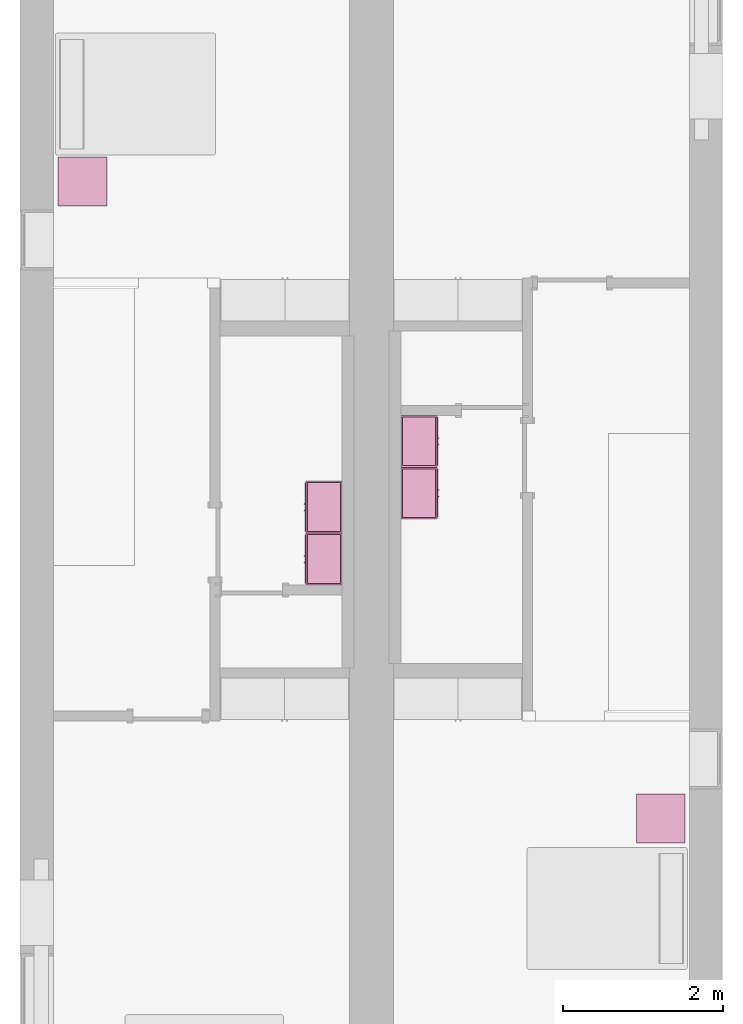
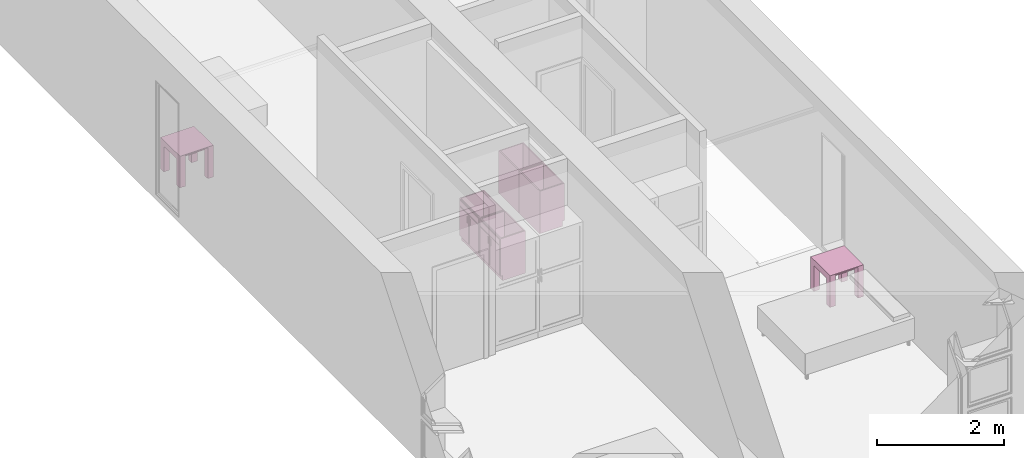
# One storey, part 10 of 16: 6 furnishings.
"""IFC2X3 building model written with IfcOpenShell, lengths in metres."""

import ifcopenshell
import ifcopenshell.guid

model = None  # the IFC model being written
_history = None  # IfcOwnerHistory: only IFC2X3 demands one
_inside = {}  # id of a spatial element -> (the spatial element, [elements in it])
_under = {}  # id of a project, library or spatial element -> (it, [spatial elements below it])
_declared = {}  # id of a project -> (the project, [libraries it declares])
_typed = {}  # id of a type object -> (the type object, [elements of that type])
_made_of = {}  # id of a material, layer set ... -> (it, [elements and type objects made of it])


def new_model(schema):
    """Start an empty IFC model of exactly this schema.

    Asked for "IFC4X3", IfcOpenShell would pick the latest addendum, in which some entities
    have other attributes; the version numbers below select the first issue.
    IFC2X3 requires an IfcOwnerHistory on every rooted entity: one is made here for all.
    """
    global model, _history
    if schema == "IFC4X3":
        model = ifcopenshell.file(schema_version=(4, 3, 0, 0))
    else:
        model = ifcopenshell.file(schema=schema)
    _inside.clear()
    _under.clear()
    _declared.clear()
    _typed.clear()
    _made_of.clear()
    _history = None
    if model.schema == "IFC2X3":
        org = make("IfcOrganization", Name="unknown")
        user = make(
            "IfcPersonAndOrganization",
            ThePerson=make("IfcPerson", FamilyName="unknown"),
            TheOrganization=org,
        )
        app = make(
            "IfcApplication",
            ApplicationDeveloper=org,
            Version="unknown",
            ApplicationFullName="unknown",
            ApplicationIdentifier="unknown",
        )
        _history = make(
            "IfcOwnerHistory",
            OwningUser=user,
            OwningApplication=app,
            ChangeAction="ADDED",
            CreationDate=0,
        )
    return model


def make(cls, **values):
    """One entity of the class cls with the attributes given. An attribute that is None is left unset."""
    return model.create_entity(
        cls, **{name: value for name, value in values.items() if value is not None}
    )


def entity(cls, *values):
    """Any entity or typed value of the class cls, its attributes in the order of the schema. None: left unset."""
    e = model.create_entity(cls)
    for i, value in enumerate(values):
        if value is not None:
            e[i] = value
    return e


def rooted(cls, **values):
    """An entity with a GlobalId (a new one), such as an element, a storey or a relation."""
    return make(cls, GlobalId=ifcopenshell.guid.new(), OwnerHistory=_history, **values)


def si_unit(unit_type, name, prefix=None):
    """IfcSIUnit, for example si_unit("LENGTHUNIT", "METRE", prefix="MILLI")."""
    return make("IfcSIUnit", UnitType=unit_type, Prefix=prefix, Name=name)


def converted_unit(unit_type, name, factor, base, dimensions=None, offset=None):
    """IfcConversionBasedUnit, such as the inch: factor (a typed value) times the base unit."""
    return make(
        "IfcConversionBasedUnit"
        if offset is None
        else "IfcConversionBasedUnitWithOffset",
        ConversionOffset=offset,
        Dimensions=None
        if dimensions is None
        else entity("IfcDimensionalExponents", *dimensions),
        UnitType=unit_type,
        Name=name,
        ConversionFactor=make(
            "IfcMeasureWithUnit", ValueComponent=factor, UnitComponent=base
        ),
    )


def assignment(units):
    """IfcUnitAssignment: the units of a project."""
    return None if units is None else make("IfcUnitAssignment", Units=units)


def point(xyz):
    """IfcCartesianPoint."""
    return None if xyz is None else make("IfcCartesianPoint", Coordinates=xyz)


def direction(xyz):
    """IfcDirection."""
    return None if xyz is None else make("IfcDirection", DirectionRatios=xyz)


def frame(location, z_axis=None, x_axis=None):
    """IfcAxis2Placement3D, a coordinate frame: its origin and axes. An axis left out is left unset."""
    return make(
        "IfcAxis2Placement3D",
        Location=point(location),
        Axis=direction(z_axis),
        RefDirection=direction(x_axis),
    )


def frame_2d(location, x_axis=None):
    """IfcAxis2Placement2D, a coordinate frame in the plane: its origin and x axis."""
    return make(
        "IfcAxis2Placement2D", Location=point(location), RefDirection=direction(x_axis)
    )


def origin():
    """The frame at (0, 0, 0) with its axes left unset."""
    return frame((0.0, 0.0, 0.0))


def origin_2d_with_axis():
    """The frame at (0, 0) in the plane with the x axis (1, 0) written out."""
    return frame_2d((0.0, 0.0), x_axis=(1.0, 0.0))


def place(relative_to, where):
    """IfcLocalPlacement: puts the frame where relative to a parent placement (None: the world)."""
    return make(
        "IfcLocalPlacement", PlacementRelTo=relative_to, RelativePlacement=where
    )


def context(
    kind, dimensions, precision=None, world=None, true_north=None, identifier=None
):
    """IfcGeometricRepresentationContext, for example the 3D "Model" context."""
    return make(
        "IfcGeometricRepresentationContext",
        ContextIdentifier=identifier,
        ContextType=kind,
        CoordinateSpaceDimension=dimensions,
        Precision=precision,
        WorldCoordinateSystem=world,
        TrueNorth=true_north,
    )


def project(units=None, contexts=None):
    """IfcProject with its units and contexts."""
    return rooted(
        "IfcProject",
        Name="project",
        RepresentationContexts=contexts,
        UnitsInContext=assignment(units),
    )


def spatial(cls, under=None, at=None, **own):
    """A site, building, storey or space (cls), placed at a placement, below another one or the project."""
    s = rooted(cls, ObjectPlacement=at, **own)
    if under is not None:
        _under.setdefault(under.id(), (under, []))[1].append(s)
    return s


def polyline(points):
    """IfcPolyline through the points."""
    return make("IfcPolyline", Points=[point(p) for p in points])


def profile(cls, at=None, kind="AREA", **sizes):
    """A parametric profile (cls). Its sizes go by their IFC names, for example OverallWidth=200.0."""
    return make(cls, ProfileType=kind, Position=at, **sizes)


def rectangle(**sizes):
    """IfcRectangleProfileDef."""
    return profile("IfcRectangleProfileDef", **sizes)


def outline(outer, holes=None, kind="AREA"):
    """IfcArbitraryClosedProfileDef: a profile drawn as a closed curve; with holes, ...WithVoids."""
    if holes is None:
        return make("IfcArbitraryClosedProfileDef", ProfileType=kind, OuterCurve=outer)
    return make(
        "IfcArbitraryProfileDefWithVoids",
        ProfileType=kind,
        OuterCurve=outer,
        InnerCurves=holes,
    )


def extrude(swept, where, along, depth):
    """IfcExtrudedAreaSolid: the profile swept, set in the frame where, extruded along a direction by depth."""
    return make(
        "IfcExtrudedAreaSolid",
        SweptArea=swept,
        Position=where,
        ExtrudedDirection=direction(along),
        Depth=depth,
    )


def faces_of(points, faces, orient=None, outer=None):
    """IfcFace entities. A face is a list of loops; a loop is a list of indices into points, from 0.

    orient and outer hold one flag for each loop. By default every Orientation is true, the
    first loop of a face is its IfcFaceOuterBound and the others are IfcFaceBound.
    """
    made = []
    for i, loops in enumerate(faces):
        bounds = []
        for j, loop in enumerate(loops):
            is_outer = j == 0 if outer is None else outer[i][j]
            bounds.append(
                make(
                    "IfcFaceOuterBound" if is_outer else "IfcFaceBound",
                    Bound=make("IfcPolyLoop", Polygon=[points[k] for k in loop]),
                    Orientation=True if orient is None else orient[i][j],
                )
            )
        made.append(make("IfcFace", Bounds=bounds))
    return made


def face_set(faces, orient=None, outer=None):
    """The faces of one IfcConnectedFaceSet. surface_model builds it on its shared points."""
    return ("IfcConnectedFaceSet", faces, orient, outer)


def surface_model(cls, points, shells):
    """IfcFaceBasedSurfaceModel or IfcShellBasedSurfaceModel (cls): surfaces that need not close."""
    shared = [point(p) for p in points]
    made = [make(c, CfsFaces=faces_of(shared, fs, o, b)) for c, fs, o, b in shells]
    if cls == "IfcFaceBasedSurfaceModel":
        return make(cls, FbsmFaces=made)
    return make(cls, SbsmBoundary=made)


def shape(context_of_items, identifier, shape_type, items):
    """IfcShapeRepresentation: the items that make up one representation, for example the "Body"."""
    return make(
        "IfcShapeRepresentation",
        ContextOfItems=context_of_items,
        RepresentationIdentifier=identifier,
        RepresentationType=shape_type,
        Items=items,
    )


def source(mapping_origin, context_of_items, identifier, shape_type, items):
    """IfcRepresentationMap: a shape defined once, which mapped items show again and again."""
    return make(
        "IfcRepresentationMap",
        MappingOrigin=mapping_origin,
        MappedRepresentation=shape(context_of_items, identifier, shape_type, items),
    )


def transform(
    local_origin,
    x_axis=None,
    y_axis=None,
    z_axis=None,
    scale=None,
    scale2=None,
    scale3=None,
    uniform=True,
):
    """IfcCartesianTransformationOperator3D, or its non-uniform kind. x_axis, y_axis, z_axis: its Axis1, 2, 3."""
    if uniform:
        return make(
            "IfcCartesianTransformationOperator3D",
            Axis1=direction(x_axis),
            Axis2=direction(y_axis),
            LocalOrigin=point(local_origin),
            Scale=scale,
            Axis3=direction(z_axis),
        )
    return make(
        "IfcCartesianTransformationOperator3DnonUniform",
        Axis1=direction(x_axis),
        Axis2=direction(y_axis),
        LocalOrigin=point(local_origin),
        Scale=scale,
        Axis3=direction(z_axis),
        Scale2=scale2,
        Scale3=scale3,
    )


def mapped(mapping_source, mapping_target):
    """IfcMappedItem: shows the shape of a source again, moved by a transform."""
    return make(
        "IfcMappedItem", MappingSource=mapping_source, MappingTarget=mapping_target
    )


def made_of(thing, what):
    """Note that an element or type object is made of a material, layer set ...; save() writes the relation."""
    if what is not None:
        _made_of.setdefault(what.id(), (what, []))[1].append(thing)
    return thing


def type_object(cls, material=None, **own):
    """A type object (cls), such as IfcWallType, which elements share."""
    return made_of(rooted(cls, **own), material)


def type_shapes(of_type, sources):
    """Give a type object the sources (RepresentationMaps) that its elements show as mapped items."""
    of_type.RepresentationMaps = sources


def element(
    cls,
    number,
    at=None,
    inside=None,
    cuts=None,
    type_object=None,
    material=None,
    context=None,
    identifier="Body",
    shape_type=None,
    held_by="IfcProductDefinitionShape",
    body=None,
    shapes=None,
    **own,
):
    """One element of the class cls, such as IfcWall. Its Tag is "e" and its number.

    at: its placement. inside: the storey or other place that contains it. cuts: it is an
    opening in that element (IfcRelVoidsElement). A single representation is given by context,
    identifier, shape_type and body (its items); several are given by shapes. held_by: the class
    of the entity that holds the representations. save() writes the other relations.
    """
    e = rooted(cls, Tag="e%d" % number, ObjectPlacement=at, **own)
    if body is not None:
        shapes = [shape(context, identifier, shape_type, body)]
    if shapes is not None:
        e.Representation = make(held_by, Representations=shapes)
    if inside is not None:
        _inside.setdefault(inside.id(), (inside, []))[1].append(e)
    if cuts is not None:
        rooted(
            "IfcRelVoidsElement", RelatingBuildingElement=cuts, RelatedOpeningElement=e
        )
    if type_object is not None:
        _typed.setdefault(type_object.id(), (type_object, []))[1].append(e)
    return made_of(e, material)


def aggregate(whole, parts):
    """IfcRelAggregates: a whole, such as a stair, and the parts it consists of."""
    return rooted("IfcRelAggregates", RelatingObject=whole, RelatedObjects=parts)


def save(model, path):
    """Write the relations noted so far, then the file.

    IfcRelAggregates (storeys below a building ...), IfcRelContainedInSpatialStructure (elements
    in a storey), IfcRelDefinesByType, IfcRelAssociatesMaterial and IfcRelDeclares: one each for
    every whole, place, type object, material and project.
    """
    for whole, parts in _under.values():
        aggregate(whole, parts)
    for where, things in _inside.values():
        rooted(
            "IfcRelContainedInSpatialStructure",
            RelatedElements=things,
            RelatingStructure=where,
        )
    for kind, things in _typed.values():
        rooted("IfcRelDefinesByType", RelatedObjects=things, RelatingType=kind)
    for what, things in _made_of.values():
        rooted("IfcRelAssociatesMaterial", RelatedObjects=things, RelatingMaterial=what)
    for by, libraries in _declared.values():
        rooted("IfcRelDeclares", RelatingContext=by, RelatedDefinitions=libraries)
    model.write(path)


model = new_model("IFC2X3")

# Units and contexts
model_context = context("Model", 3, precision=1e-09, world=origin())
plan_context = context("Plan", 3, precision=1e-09, world=origin())
ifc_project = project(units=[si_unit("LENGTHUNIT", "METRE"), si_unit("AREAUNIT", "SQUARE_METRE"), si_unit("VOLUMEUNIT", "CUBIC_METRE"), converted_unit("PLANEANGLEUNIT", "DEGREE", entity("IfcRatioMeasure", 0.01745329251994328), si_unit("PLANEANGLEUNIT", "RADIAN"), dimensions=[0, 0, 0, 0, 0, 0, 0]), si_unit("TIMEUNIT", "SECOND")], contexts=[model_context, plan_context])

# Site, building, storey, space
site_placement = place(None, origin())
site = spatial("IfcSite", under=ifc_project, at=site_placement, CompositionType="ELEMENT")
building_placement = place(site_placement, origin())
building = spatial("IfcBuilding", under=site, at=building_placement, CompositionType="ELEMENT")
storey_placement = place(building_placement, frame((0.0, 0.0, 3.100000000000196)))
storey = spatial("IfcBuildingStorey", under=building, at=storey_placement, Name="Level 2", CompositionType="ELEMENT", Elevation=3.100000000000196)
space_1_placement = place(storey_placement, origin())
space_1 = spatial("IfcSpace", under=storey, at=space_1_placement, CompositionType="ELEMENT", InteriorOrExteriorSpace="INTERNAL")

# Furnishing
furniture_type_1 = type_object("IfcFurnitureType", Name="0610 x 0610 x 0610mm", AssemblyPlace="NOTDEFINED")
shared_shape_1 = source(origin(), model_context, "Body", "SweptSolid", [
    extrude(rectangle(XDim=0.4067999999999992, YDim=0.4067999999999995, at=origin_2d_with_axis()), frame((0.01826576667263163, 0.09521107780222626, 0.4957000000000002), z_axis=(0.0, 0.0, 1.0), x_axis=(-1.0, 0.0, 0.0)), (0.0, 0.0, 1.0), 0.01270000000000002),
    extrude(outline(polyline([(-0.2732499999999937, -0.3050000000000002), (0.3240499999999779, -0.3050000000000002), (0.3240499999999779, 0.3049999999999985), (-0.2732499999999932, 0.3049999999999986), (-0.2732499999999932, 0.2034000000000015), (0.2224500000000091, 0.2034000000000015), (0.2224500000000091, -0.2033999999999998), (-0.2732499999999936, -0.2033999999999998), (-0.2732499999999937, -0.3050000000000002)])), frame((0.2216657666726329, 0.09521107780223541, 0.2732499999999923), z_axis=(1.0, 0.0, 0.0), x_axis=(0.0, 0.0, 1.0)), (0.0, 0.0, 1.0), 0.1016),
    extrude(outline(polyline([(-0.3050000000000043, -0.3240500000000255), (0.3049999999999944, -0.3240500000000255), (0.3049999999999944, 0.2732500000000109), (0.2034000000000044, 0.2732500000000109), (0.2034000000000044, -0.2224499999999962), (-0.2033999999999945, -0.2224499999999962), (-0.2033999999999945, 0.2732500000000109), (-0.3050000000000043, 0.2732500000000109), (-0.3050000000000043, -0.3240500000000255)])), frame((-0.2867342333273671, 0.09521107780222562, 0.2732500000000078), z_axis=(1.0, 0.0, 0.0), x_axis=(0.0, -1.0, 0.0)), (0.0, 0.0, 1.0), 0.1016),
    extrude(rectangle(XDim=0.4067999999999992, YDim=0.4067999999999995, at=origin_2d_with_axis()), frame((0.01826576667263163, 0.09521107780222593, 0.5973000000000002), z_axis=(0.0, 0.0, 1.0), x_axis=(-1.0, 0.0, 0.0)), (0.0, 0.0, 1.0), 0.01270000000000002),
    extrude(outline(polyline([(-0.3050000000000005, -0.3050000000000226), (0.3050000000000004, -0.3050000000000226), (0.3050000000000005, 0.3050000000000226), (-0.3050000000000004, 0.3050000000000226), (-0.3050000000000005, -0.3050000000000226)]), holes=[polyline([(-0.203399999999998, -0.2033999999999748), (-0.2033999999999979, 0.2034000000000246), (0.2034000000000013, 0.2034000000000245), (0.2034000000000012, -0.2033999999999749), (-0.203399999999998, -0.2033999999999748)])]), frame((0.01826576667263323, 0.09521107780225081, 0.5973000000000003), z_axis=(0.0, 0.0, 1.0), x_axis=(-1.0, 0.0, 0.0)), (0.0, 0.0, 1.0), 0.01269999999999996),
])
type_shapes(furniture_type_1, [shared_shape_1])
furnishing_1_placement = place(space_1_placement, frame((0.7637342333273673, -5.012211077802231, 0.01900000000000013)))
element("IfcFurnishingElement", 1, at=furnishing_1_placement, inside=space_1, type_object=furniture_type_1, Name="M_Table-Coffee:0610 x 0610 x 0610mm:0610 x 0610 x 0610mm", ObjectType="0610 x 0610 x 0610mm", context=model_context, shape_type="MappedRepresentation", body=[
    mapped(shared_shape_1, transform((0.0, 0.0, 0.0), scale=1.0)),
])

# Space
space_2_placement = place(storey_placement, origin())
space_2 = spatial("IfcSpace", under=storey, at=space_2_placement, CompositionType="ELEMENT", InteriorOrExteriorSpace="INTERNAL")

# Furnishing
furnishing_2_placement = place(space_2_placement, frame((8.004734233327348, -12.98921107780223, 0.01900000000000013)))
element("IfcFurnishingElement", 2, at=furnishing_2_placement, inside=space_2, type_object=furniture_type_1, Name="M_Table-Coffee:0610 x 0610 x 0610mm:0610 x 0610 x 0610mm", ObjectType="0610 x 0610 x 0610mm", context=model_context, shape_type="MappedRepresentation", body=[
    mapped(shared_shape_1, transform((0.0, 0.0, 0.0), scale=1.0)),
])

# Space
space_3_placement = place(storey_placement, origin())
space_3 = spatial("IfcSpace", under=storey, at=space_3_placement, CompositionType="ELEMENT", InteriorOrExteriorSpace="INTERNAL")

# Furnishings
furniture_type_2 = type_object("IfcFurnitureType", Name="650 x 450 mm", AssemblyPlace="NOTDEFINED")
shared_shape_2 = source(origin(), model_context, "Body", "SurfaceModel", [
    surface_model("IfcFaceBasedSurfaceModel", [(0.6309500000000011, 0.04444999999999903, 0.8199999999999998), (0.6309500000000011, 0.04444999999999903, 0.09999999999999946), (0.01904999999999871, 0.04444999999999903, 0.09999999999999946), (0.01904999999999871, 0.04444999999999903, 0.8199999999999998), (0.6499999999999999, 0.02540000000000032, 0.8199999999999998), (0.0, 0.02540000000000032, 0.8199999999999998), (0.6499999999999999, 0.02540000000000032, 0.09999999999999946), (0.0, 0.02540000000000032, 0.09999999999999946), (0.01904999999999871, 0.4563500000000013, 0.8199999999999998), (0.01904999999999871, 0.4563500000000013, 0.09999999999999944), (0.01904999999999871, 0.06040000000000224, 0.09999999999999946), (0.0, 0.4754, 0.8199999999999998), (0.0, 0.4754, 0.0), (0.0, 0.06040000000000224, 0.0), (0.0, 0.06040000000000224, 0.09999999999999944), (0.6309500000000011, 0.4563500000000013, 0.8199999999999998), (0.6309500000000011, 0.4563500000000013, 0.09999999999999944), (0.6499999999999998, 0.4754, 0.8199999999999998), (0.6499999999999999, 0.4754, 0.0), (0.6309500000000011, 0.06040000000000224, 0.09999999999999944), (0.6499999999999999, 0.06040000000000224, 0.09999999999999946), (0.6499999999999999, 0.06040000000000224, 0.0), (0.2900749999999994, 0.0, 0.6422000000000013), (0.2900749999999994, 0.0, 0.5174698950351613), (0.2773749999999991, 0.0, 0.5174698950351613), (0.2773749999999991, 0.0, 0.6422000000000013), (0.3726249999999207, 0.0, 0.6422000000000011), (0.3726249999999207, 0.0, 0.5174698950351634), (0.3599249999999205, 0.0, 0.5174698950351634), (0.3599249999999205, 0.0, 0.6422000000000011), (0.2900749999999994, 0.01270000000000029, 0.6422000000000013), (0.2900749999999994, 0.01270000000000029, 0.5174698950351613), (0.2773749999999991, 0.01270000000000036, 0.5174698950351613), (0.2773749999999991, 0.01270000000000036, 0.6422000000000013), (0.3726249999999207, 0.01270000000000002, 0.6422000000000011), (0.3726249999999207, 0.01270000000000002, 0.5174698950351634), (0.3599249999999206, 0.01270000000000009, 0.5174698950351634), (0.3599249999999206, 0.01270000000000009, 0.6422000000000011), (0.3154749999998973, 0.01270000000000029, 0.6803000000000058), (0.3154749999998973, 0.01270000000000029, 0.1190499999998422), (0.01905000000047931, 0.01270000000000124, 0.1190499999998422), (0.01905000000047931, 0.01270000000000124, 0.6803000000000058), (0.6309500000005075, 0.01269999999999928, 0.6803000000000425), (0.6309500000005075, 0.01269999999999928, 0.1190499999998571), (0.3345249999998469, 0.01270000000000023, 0.1190499999998571), (0.3345249999998469, 0.01270000000000023, 0.6803000000000425), (0.6309500000005104, 0.01269999999999928, 0.8009500000000862), (0.6309500000005104, 0.01269999999999928, 0.699350000000061), (0.01905000000049125, 0.01270000000000124, 0.699350000000061), (0.01905000000049122, 0.01270000000000124, 0.8009500000000862), (0.3154749999998973, 0.02540000000000032, 0.6803000000000058), (0.3154749999998973, 0.02540000000000032, 0.1190499999998422), (0.01905000000047934, 0.02540000000000127, 0.1190499999998422), (0.01905000000047934, 0.02540000000000127, 0.6803000000000058), (0.6309500000005075, 0.0253999999999993, 0.6803000000000425), (0.6309500000005075, 0.0253999999999993, 0.1190499999998571), (0.3345249999998469, 0.02540000000000025, 0.1190499999998571), (0.3345249999998469, 0.02540000000000025, 0.6803000000000425), (0.6309500000005104, 0.0253999999999993, 0.8009500000000862), (0.6309500000005104, 0.0253999999999993, 0.699350000000061), (0.01905000000049135, 0.02540000000000127, 0.699350000000061), (0.01905000000049129, 0.02540000000000127, 0.8009500000000862), (0.6309500000000011, 0.4563500000000013, 0.119049999999842), (0.6309500000000011, 0.04444999999999903, 0.119049999999842), (0.01904999999999871, 0.04444999999999903, 0.119049999999842), (0.01904999999999871, 0.4563500000000013, 0.119049999999842), (0.6309500000000011, 0.4563500000000013, 0.09999999999999944), (0.6309500000000011, 0.04444999999999903, 0.09999999999999944), (0.01904999999999871, 0.04444999999999903, 0.09999999999999944), (0.01904999999999871, 0.4563500000000013, 0.09999999999999944)], [face_set([[[0, 1, 2, 3]], [[0, 4, 5, 3]], [[4, 6, 7, 5]], [[2, 1, 6, 7]], [[3, 8, 9, 10, 2]], [[5, 11, 8, 3]], [[7, 5, 11, 12, 13, 14]], [[2, 7, 14, 10]], [[8, 15, 16, 9]], [[11, 17, 15, 8]], [[12, 11, 17, 18]], [[1, 19, 16, 15, 0]], [[0, 15, 17, 4]], [[4, 6, 20, 21, 18, 17]], [[6, 1, 19, 20]], [[10, 9, 16, 19]], [[18, 21, 13, 12]], [[13, 14, 10, 19, 20, 21]]]), face_set([[[22, 23, 24, 25]], [[26, 27, 28, 29]], [[30, 31, 32, 33]], [[34, 35, 36, 37]], [[25, 33, 30, 22]], [[24, 32, 33, 25]], [[23, 24, 32, 31]], [[22, 23, 31, 30]], [[29, 37, 34, 26]], [[28, 36, 37, 29]], [[27, 28, 36, 35]], [[26, 27, 35, 34]]]), face_set([[[38, 39, 40, 41]], [[42, 43, 44, 45]], [[46, 47, 48, 49]], [[50, 51, 52, 53]], [[54, 55, 56, 57]], [[58, 59, 60, 61]], [[41, 53, 50, 38]], [[40, 41, 53, 52]], [[39, 40, 52, 51]], [[38, 39, 51, 50]], [[45, 57, 54, 42]], [[44, 56, 57, 45]], [[43, 44, 56, 55]], [[42, 43, 55, 54]], [[49, 61, 58, 46]], [[48, 49, 61, 60]], [[47, 48, 60, 59]], [[46, 47, 59, 58]]]), face_set([[[62, 63, 64, 65]], [[66, 67, 68, 69]], [[65, 62, 66, 69]], [[64, 65, 69, 68]], [[63, 67, 68, 64]], [[62, 63, 67, 66]]])]),
])
type_shapes(furniture_type_2, [shared_shape_2])
for number, where, z_axis, x_axis in (
    (3, (3.554599999999983, -9.32005117851059, 0.0129999999999999), (0.0, 0.0, 1.0), (0.0, -1.0, 0.0)),
    (4, (3.554599999999985, -8.67005117851059, 0.0129999999999999), (0.0, 0.0, 1.0), (0.0, -1.0, 0.0)),
):
    element("IfcFurnishingElement", number, at=place(space_3_placement, frame(where, z_axis=z_axis, x_axis=x_axis)), inside=space_3, type_object=furniture_type_2, ObjectType="650 x 450 mm", context=model_context, shape_type="MappedRepresentation", body=[
        mapped(shared_shape_2, transform((0.0, 0.0, 0.0), scale=1.0)),
    ])

# Space
space_4_placement = place(storey_placement, origin())
space_4 = spatial("IfcSpace", under=storey, at=space_4_placement, CompositionType="ELEMENT", InteriorOrExteriorSpace="INTERNAL")

# Furnishings
furniture_type_3 = type_object("IfcFurnitureType", Name="650 x 450 mm", AssemblyPlace="NOTDEFINED")
shared_shape_3 = source(origin(), model_context, "Body", "SurfaceModel", [
    surface_model("IfcFaceBasedSurfaceModel", [(0.6309500000000011, 0.430950000000001, 0.8199999999999998), (0.01904999999999871, 0.430950000000001, 0.8199999999999998), (0.01904999999999871, 0.430950000000001, 0.09999999999999946), (0.6309500000000011, 0.430950000000001, 0.09999999999999946), (0.0, 0.4499999999999997, 0.8199999999999998), (0.6499999999999999, 0.4499999999999997, 0.8199999999999998), (0.0, 0.4499999999999997, 0.09999999999999946), (0.6499999999999999, 0.4499999999999997, 0.09999999999999946), (0.01904999999999871, 0.4149999999999978, 0.09999999999999944), (0.01904999999999871, 0.01904999999999871, 0.09999999999999946), (0.01904999999999871, 0.01904999999999871, 0.8199999999999998), (0.0, 0.0, 0.8199999999999998), (0.0, 0.0, 0.0), (0.0, 0.4149999999999978, 0.0), (0.0, 0.4149999999999978, 0.09999999999999946), (0.6309500000000011, 0.01904999999999869, 0.09999999999999946), (0.6309500000000011, 0.01904999999999869, 0.8199999999999998), (0.6499999999999999, 0.0, 0.8199999999999998), (0.6499999999999999, 0.0, 0.0), (0.6309500000000011, 0.4149999999999978, 0.09999999999999946), (0.6499999999999999, 0.4149999999999978, 0.0), (0.6499999999999999, 0.4149999999999978, 0.09999999999999946), (0.2900749999999994, 0.4753999999999998, 0.6422000000000013), (0.2773749999999991, 0.4753999999999997, 0.6422000000000013), (0.2773749999999991, 0.4753999999999997, 0.5174698950351613), (0.2900749999999994, 0.4753999999999998, 0.5174698950351613), (0.3726249999999207, 0.4754, 0.6422000000000011), (0.3599249999999205, 0.4753999999999999, 0.6422000000000011), (0.3599249999999205, 0.4753999999999999, 0.5174698950351634), (0.3726249999999207, 0.4754, 0.5174698950351634), (0.2900749999999994, 0.4626999999999997, 0.6422000000000013), (0.2773749999999991, 0.4626999999999997, 0.6422000000000013), (0.2773749999999991, 0.4626999999999997, 0.5174698950351613), (0.2900749999999994, 0.4626999999999997, 0.5174698950351613), (0.3726249999999207, 0.4627, 0.6422000000000011), (0.3599249999999206, 0.4626999999999999, 0.6422000000000011), (0.3599249999999206, 0.4626999999999999, 0.5174698950351634), (0.3726249999999207, 0.4627, 0.5174698950351634), (0.3154749999998973, 0.4626999999999997, 0.6803000000000058), (0.01905000000047931, 0.4626999999999988, 0.6803000000000058), (0.01905000000047931, 0.4626999999999988, 0.1190499999998422), (0.3154749999998973, 0.4626999999999997, 0.1190499999998422), (0.6309500000005075, 0.4627000000000007, 0.6803000000000425), (0.3345249999998469, 0.4626999999999998, 0.6803000000000425), (0.3345249999998469, 0.4626999999999998, 0.1190499999998571), (0.6309500000005075, 0.4627000000000007, 0.1190499999998571), (0.6309500000005104, 0.4627000000000007, 0.8009500000000862), (0.01905000000049125, 0.4626999999999988, 0.8009500000000862), (0.01905000000049122, 0.4626999999999988, 0.699350000000061), (0.6309500000005104, 0.4627000000000007, 0.699350000000061), (0.3154749999998973, 0.4499999999999997, 0.6803000000000058), (0.01905000000047934, 0.4499999999999987, 0.6803000000000058), (0.01905000000047934, 0.4499999999999987, 0.1190499999998422), (0.3154749999998973, 0.4499999999999997, 0.1190499999998422), (0.6309500000005075, 0.4500000000000007, 0.6803000000000425), (0.3345249999998469, 0.4499999999999998, 0.6803000000000425), (0.3345249999998469, 0.4499999999999998, 0.1190499999998571), (0.6309500000005075, 0.4500000000000007, 0.1190499999998571), (0.6309500000005104, 0.4500000000000007, 0.8009500000000862), (0.01905000000049135, 0.4499999999999987, 0.8009500000000862), (0.01905000000049129, 0.4499999999999987, 0.699350000000061), (0.6309500000005104, 0.4500000000000007, 0.699350000000061), (0.6309500000000011, 0.01904999999999871, 0.119049999999842), (0.01904999999999871, 0.01904999999999871, 0.119049999999842), (0.01904999999999871, 0.430950000000001, 0.119049999999842), (0.6309500000000011, 0.430950000000001, 0.119049999999842), (0.6309500000000011, 0.01904999999999872, 0.09999999999999944), (0.01904999999999871, 0.01904999999999871, 0.09999999999999944), (0.01904999999999871, 0.430950000000001, 0.09999999999999944), (0.6309500000000011, 0.430950000000001, 0.09999999999999944)], [face_set([[[0, 1, 2, 3]], [[0, 1, 4, 5]], [[5, 4, 6, 7]], [[2, 6, 7, 3]], [[1, 2, 8, 9, 10]], [[4, 1, 10, 11]], [[6, 4, 11, 12, 13, 14]], [[2, 8, 14, 6]], [[10, 9, 15, 16]], [[11, 10, 16, 17]], [[12, 18, 17, 11]], [[3, 0, 16, 15, 19]], [[0, 5, 17, 16]], [[5, 17, 18, 20, 21, 7]], [[7, 21, 19, 3]], [[8, 19, 15, 9]], [[18, 12, 13, 20]], [[13, 20, 21, 19, 8, 14]]]), face_set([[[22, 23, 24, 25]], [[26, 27, 28, 29]], [[30, 31, 32, 33]], [[34, 35, 36, 37]], [[23, 22, 30, 31]], [[24, 23, 31, 32]], [[25, 33, 32, 24]], [[22, 30, 33, 25]], [[27, 26, 34, 35]], [[28, 27, 35, 36]], [[29, 37, 36, 28]], [[26, 34, 37, 29]]]), face_set([[[38, 39, 40, 41]], [[42, 43, 44, 45]], [[46, 47, 48, 49]], [[50, 51, 52, 53]], [[54, 55, 56, 57]], [[58, 59, 60, 61]], [[39, 38, 50, 51]], [[40, 52, 51, 39]], [[41, 53, 52, 40]], [[38, 50, 53, 41]], [[43, 42, 54, 55]], [[44, 43, 55, 56]], [[45, 57, 56, 44]], [[42, 54, 57, 45]], [[47, 46, 58, 59]], [[48, 60, 59, 47]], [[49, 61, 60, 48]], [[46, 58, 61, 49]]]), face_set([[[62, 63, 64, 65]], [[66, 67, 68, 69]], [[63, 67, 66, 62]], [[64, 68, 67, 63]], [[65, 64, 68, 69]], [[62, 66, 69, 65]]])]),
])
type_shapes(furniture_type_3, [shared_shape_3])
for number, where, z_axis, x_axis in (
    (5, (4.770000000000017, -8.495384235071528, 0.0129999999999999), (0.0, 0.0, 1.0), (0.0, -1.0, 0.0)),
    (6, (4.770000000000015, -7.845384235071528, 0.0129999999999999), (0.0, 0.0, 1.0), (0.0, -1.0, 0.0)),
):
    element("IfcFurnishingElement", number, at=place(space_4_placement, frame(where, z_axis=z_axis, x_axis=x_axis)), inside=space_4, type_object=furniture_type_3, ObjectType="650 x 450 mm", context=model_context, shape_type="MappedRepresentation", body=[
        mapped(shared_shape_3, transform((0.0, 0.0, 0.0), scale=1.0)),
    ])

save(model, "model.ifc")
